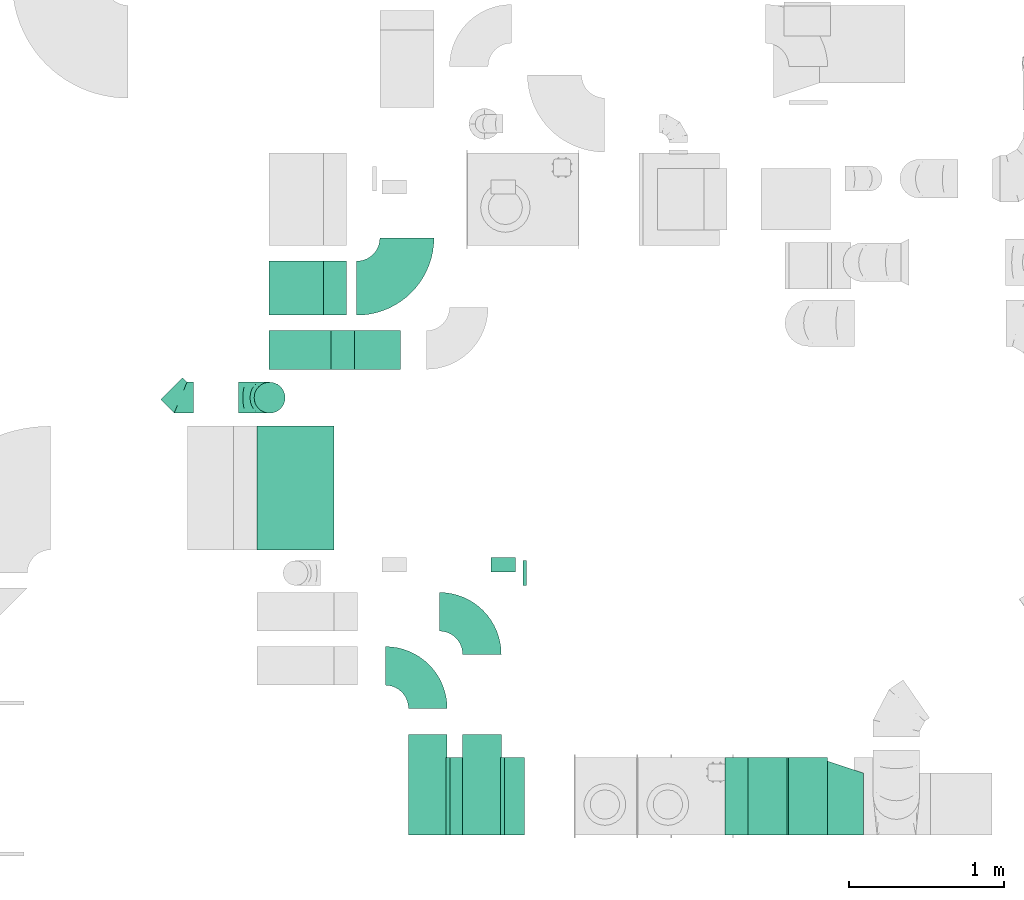
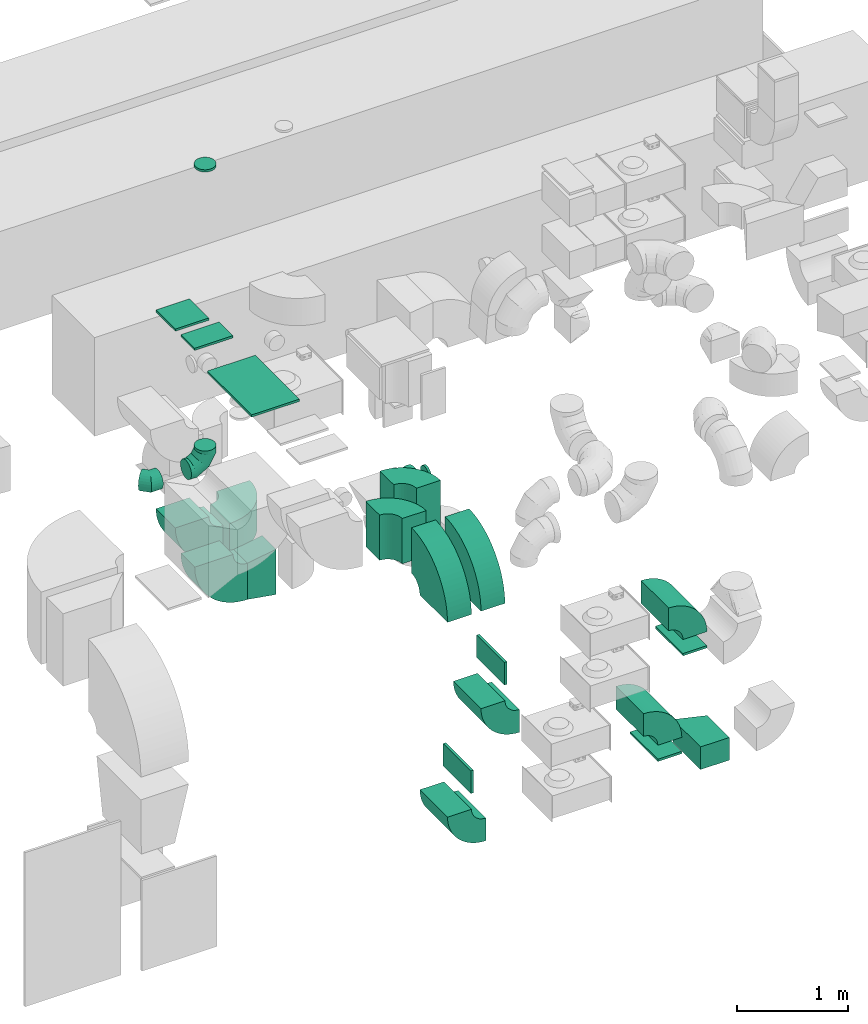
# One storey, part 8 of 59: 25 flow fittings.
"""IFC2X3 building model written with IfcOpenShell, lengths in millimetres."""

from ifc_helpers import new_model, entity, si_unit, converted_unit, derived_unit, direction, frame, frame_2d, origin, origin_2d_with_axis, place, context, subcontext, project, spatial, polyline, circle_curve, parameter, trimmed, segment, composite_curve, rectangle, circle, outline, extrude, faceted_brep, source, transform, mapped, material, type_object, type_shapes, element, save


model = new_model("IFC2X3")

# Units and contexts
model_context = context("Model", 3, precision=0.01, world=origin(), true_north=direction((6.12303176911189e-17, 1.0)))
body_context = subcontext(model_context, "Body", "Model", "MODEL_VIEW")
ifc_project = project(units=[si_unit("LENGTHUNIT", "METRE", prefix="MILLI"), si_unit("AREAUNIT", "SQUARE_METRE"), si_unit("VOLUMEUNIT", "CUBIC_METRE"), converted_unit("PLANEANGLEUNIT", "DEGREE", entity("IfcRatioMeasure", 0.0174532925199433), si_unit("PLANEANGLEUNIT", "RADIAN"), dimensions=[0, 0, 0, 0, 0, 0, 0]), si_unit("MASSUNIT", "GRAM", prefix="KILO"), derived_unit("MASSDENSITYUNIT", [(si_unit("MASSUNIT", "GRAM", prefix="KILO"), 1), (si_unit("LENGTHUNIT", "METRE"), -3)]), derived_unit("MOMENTOFINERTIAUNIT", [(si_unit("LENGTHUNIT", "METRE"), 4)]), si_unit("TIMEUNIT", "SECOND"), si_unit("FREQUENCYUNIT", "HERTZ"), si_unit("THERMODYNAMICTEMPERATUREUNIT", "DEGREE_CELSIUS"), derived_unit("THERMALTRANSMITTANCEUNIT", [(si_unit("MASSUNIT", "GRAM", prefix="KILO"), 1), (si_unit("THERMODYNAMICTEMPERATUREUNIT", "KELVIN"), -1), (si_unit("TIMEUNIT", "SECOND"), -3)]), derived_unit("VOLUMETRICFLOWRATEUNIT", [(si_unit("LENGTHUNIT", "METRE"), 3), (si_unit("TIMEUNIT", "SECOND"), -1)]), derived_unit("MASSFLOWRATEUNIT", [(si_unit("MASSUNIT", "GRAM", prefix="KILO"), 1), (si_unit("TIMEUNIT", "SECOND"), -1)]), derived_unit("ROTATIONALFREQUENCYUNIT", [(si_unit("TIMEUNIT", "SECOND"), -1)]), si_unit("ELECTRICCURRENTUNIT", "AMPERE"), si_unit("ELECTRICVOLTAGEUNIT", "VOLT"), si_unit("POWERUNIT", "WATT"), si_unit("FORCEUNIT", "NEWTON", prefix="KILO"), si_unit("ILLUMINANCEUNIT", "LUX"), si_unit("LUMINOUSFLUXUNIT", "LUMEN"), si_unit("LUMINOUSINTENSITYUNIT", "CANDELA"), derived_unit("USERDEFINED", [(si_unit("MASSUNIT", "GRAM", prefix="KILO"), -1), (si_unit("LENGTHUNIT", "METRE"), -2), (si_unit("TIMEUNIT", "SECOND"), 3), (si_unit("LUMINOUSFLUXUNIT", "LUMEN"), 1)]), derived_unit("LINEARVELOCITYUNIT", [(si_unit("LENGTHUNIT", "METRE"), 1), (si_unit("TIMEUNIT", "SECOND"), -1)]), si_unit("PRESSUREUNIT", "PASCAL"), derived_unit("USERDEFINED", [(si_unit("LENGTHUNIT", "METRE"), -2), (si_unit("MASSUNIT", "GRAM", prefix="KILO"), 1), (si_unit("TIMEUNIT", "SECOND"), -2)]), derived_unit("LINEARFORCEUNIT", [(si_unit("MASSUNIT", "GRAM", prefix="KILO"), 1), (si_unit("LENGTHUNIT", "METRE"), 1), (si_unit("TIMEUNIT", "SECOND"), -2), (si_unit("LENGTHUNIT", "METRE"), -1)]), derived_unit("PLANARFORCEUNIT", [(si_unit("MASSUNIT", "GRAM", prefix="KILO"), 1), (si_unit("LENGTHUNIT", "METRE"), 1), (si_unit("TIMEUNIT", "SECOND"), -2), (si_unit("LENGTHUNIT", "METRE"), -2)])], contexts=[model_context])

# Site, building, storey
site_placement = place(None, origin())
site = spatial("IfcSite", under=ifc_project, at=site_placement, CompositionType="ELEMENT")
building_placement = place(site_placement, origin())
building = spatial("IfcBuilding", under=site, at=building_placement, CompositionType="ELEMENT")
storey_placement = place(building_placement, frame((0.0, 0.0, 28200.0)))
storey = spatial("IfcBuildingStorey", under=building, at=storey_placement, CompositionType="ELEMENT", Elevation=28200.0)

# Flow fittings
ifc_material = material()
duct_fitting_type_1 = type_object("IfcDuctFittingType", PredefinedType="NOTDEFINED", material=ifc_material)
shared_shape_1 = source(origin(), body_context, "Body", "SweptSolid", [
    extrude(circle(Radius=79.9999999999994, at=origin_2d_with_axis()), frame((0.0, 0.0, 0.0), z_axis=(1.0, 0.0, 0.0), x_axis=(0.0, 1.0, 0.0)), (0.0, 0.0, 1.0), 25.0000000000018),
])
type_shapes(duct_fitting_type_1, [shared_shape_1])
flow_fitting_1_placement = place(storey_placement, frame((29294.64, 9627.84, 3205.01)))
element("IfcFlowFitting", 1, at=flow_fitting_1_placement, inside=storey, type_object=duct_fitting_type_1, material=ifc_material, context=body_context, shape_type="MappedRepresentation", body=[
    mapped(shared_shape_1, transform((0.0, 0.0, 0.0), scale=1.0)),
])
duct_fitting_type_2 = type_object("IfcDuctFittingType", PredefinedType="NOTDEFINED", material=ifc_material)
shared_shape_2 = source(origin(), body_context, "Body", "SweptSolid", [
    extrude(circle(Radius=99.9999999999994, at=origin_2d_with_axis()), frame((0.0, 0.0, 0.0), z_axis=(1.0, 0.0, 0.0), x_axis=(0.0, 1.0, 0.0)), (0.0, 0.0, 1.0), 25.0000000000018),
])
type_shapes(duct_fitting_type_2, [shared_shape_2])
flow_fitting_2_placement = place(storey_placement, frame((27656.97, 10761.91, 6490.0), z_axis=(-1.0, 0.0, 0.0), x_axis=(0.0, 0.0, 1.0)))
element("IfcFlowFitting", 2, at=flow_fitting_2_placement, inside=storey, type_object=duct_fitting_type_2, material=ifc_material, context=body_context, shape_type="MappedRepresentation", body=[
    mapped(shared_shape_2, transform((0.0, 0.0, 0.0), scale=1.0)),
])
duct_fitting_type_3 = type_object("IfcDuctFittingType", PredefinedType="NOTDEFINED", material=ifc_material)
shared_shape_3 = source(origin(), body_context, "Body", "SweptSolid", [
    extrude(outline(polyline([(-189.06, -221.94), (115.08, -221.94), (180.84, 172.62), (-106.86, 271.26), (-189.06, -221.94)])), frame((150.0, -125.0, 0.0), z_axis=(0.0, 1.0, 0.0), x_axis=(0.986393923832128, 0.0, -0.16439898730545)), (0.0, 0.0, 1.0), 250.0),
])
type_shapes(duct_fitting_type_3, [shared_shape_3])
flow_fitting_3_placement = place(storey_placement, frame((28504.24, 11070.06, 1600.0), z_axis=(0.0, 0.0, 1.0), x_axis=(-1.0, 0.0, 0.0)))
element("IfcFlowFitting", 3, at=flow_fitting_3_placement, inside=storey, type_object=duct_fitting_type_3, material=ifc_material, context=body_context, shape_type="MappedRepresentation", body=[
    mapped(shared_shape_3, transform((0.0, 0.0, 0.0), scale=1.0)),
])
duct_fitting_type_4 = type_object("IfcDuctFittingType", PredefinedType="NOTDEFINED", material=ifc_material)
shared_shape_4 = source(origin(), body_context, "Body", "SweptSolid", [
    extrude(rectangle(XDim=26.0960000000177, YDim=250.0, at=origin_2d_with_axis()), frame((6.95, 0.0, -250.0)), (0.0, 0.0, 1.0), 500.0),
])
type_shapes(duct_fitting_type_4, [shared_shape_4])
for number, where, z_axis, x_axis in (
    (4, (29155.0, 8184.5, 2075.0), (0.0, -1.0, 0.0), (1.0, 0.0, 0.0)),
    (5, (28805.03, 8184.5, 1000.0), (0.0, -1.0, 0.0), (1.0, 0.0, 0.0)),
):
    element("IfcFlowFitting", number, at=place(storey_placement, frame(where, z_axis=z_axis, x_axis=x_axis)), inside=storey, type_object=duct_fitting_type_4, material=ifc_material, context=body_context, shape_type="MappedRepresentation", body=[
        mapped(shared_shape_4, transform((0.0, 0.0, 0.0), scale=1.0)),
    ])
duct_fitting_type_5 = type_object("IfcDuctFittingType", PredefinedType="NOTDEFINED", material=ifc_material)
shared_shape_5 = source(origin(), body_context, "Body", "SweptSolid", [
    extrude(rectangle(XDim=500.0, YDim=26.0960000001386, at=origin_2d_with_axis()), frame((6.95, 0.0, -125.0), z_axis=(0.0, 0.0, 1.0), x_axis=(0.0, -1.0, 0.0)), (0.0, 0.0, 1.0), 250.0),
])
type_shapes(duct_fitting_type_5, [shared_shape_5])
for number, where, z_axis, x_axis in (
    (6, (31138.92, 8184.5, 1625.0), (-1.0, 0.0, 0.0), (0.0, 0.0, 1.0)),
    (7, (30876.33, 8184.5, 550.0), (-1.0, 0.0, 0.0), (0.0, 0.0, 1.0)),
):
    element("IfcFlowFitting", number, at=place(storey_placement, frame(where, z_axis=z_axis, x_axis=x_axis)), inside=storey, type_object=duct_fitting_type_5, material=ifc_material, context=body_context, shape_type="MappedRepresentation", body=[
        mapped(shared_shape_5, transform((0.0, 0.0, 0.0), scale=1.0)),
    ])
duct_fitting_type_6 = type_object("IfcDuctFittingType", PredefinedType="NOTDEFINED", material=ifc_material)
shared_shape_6 = source(origin(), body_context, "Body", "SweptSolid", [
    extrude(outline(polyline([(-86.97, -213.46), (229.26, -213.46), (71.16, 260.89), (-213.45, 166.02), (-86.97, -213.46)])), frame((150.0, -25.0, -125.0), z_axis=(0.0, 0.0, 1.0), x_axis=(0.948691527518346, -0.316203076542446, 0.0)), (0.0, 0.0, 1.0), 250.0),
])
type_shapes(duct_fitting_type_6, [shared_shape_6])
flow_fitting_4_placement = place(storey_placement, frame((31497.03, 8134.51, 425.0), z_axis=(0.0, 0.0, 1.0), x_axis=(-1.0, 0.0, 0.0)))
element("IfcFlowFitting", 8, at=flow_fitting_4_placement, inside=storey, type_object=duct_fitting_type_6, material=ifc_material, context=body_context, shape_type="MappedRepresentation", body=[
    mapped(shared_shape_6, transform((0.0, 0.0, 0.0), scale=1.0)),
])
duct_fitting_type_7 = type_object("IfcDuctFittingType", PredefinedType="NOTDEFINED", material=ifc_material)
shared_shape_7 = source(origin(), body_context, "Body", "SweptSolid", [
    extrude(rectangle(XDim=24.9999999999999, YDim=250.0, at=origin_2d_with_axis()), frame((12.5, 0.0, -200.0)), (0.0, 0.0, 1.0), 400.0),
])
type_shapes(duct_fitting_type_7, [shared_shape_7])
flow_fitting_5_placement = place(storey_placement, frame((27854.24, 11070.06, 4340.0), z_axis=(1.0, 0.0, 0.0), x_axis=(0.0, 0.0, 1.0)))
element("IfcFlowFitting", 9, at=flow_fitting_5_placement, inside=storey, type_object=duct_fitting_type_7, material=ifc_material, context=body_context, shape_type="MappedRepresentation", body=[
    mapped(shared_shape_7, transform((0.0, 0.0, 0.0), scale=1.0)),
])
duct_fitting_type_8 = type_object("IfcDuctFittingType", PredefinedType="NOTDEFINED", material=ifc_material)
shared_shape_8 = source(origin(), body_context, "Body", "SweptSolid", [
    extrude(rectangle(XDim=24.9999999999999, YDim=350.0, at=origin_2d_with_axis()), frame((12.5, 0.0, -175.0)), (0.0, 0.0, 1.0), 350.0),
])
type_shapes(duct_fitting_type_8, [shared_shape_8])
flow_fitting_6_placement = place(storey_placement, frame((27829.24, 11470.06, 4340.0), z_axis=(1.0, 0.0, 0.0), x_axis=(0.0, 0.0, 1.0)))
element("IfcFlowFitting", 10, at=flow_fitting_6_placement, inside=storey, type_object=duct_fitting_type_8, material=ifc_material, context=body_context, shape_type="MappedRepresentation", body=[
    mapped(shared_shape_8, transform((0.0, 0.0, 0.0), scale=1.0)),
])
duct_fitting_type_9 = type_object("IfcDuctFittingType", PredefinedType="NOTDEFINED", material=ifc_material)
shared_shape_9 = source(origin(), body_context, "Body", "SweptSolid", [
    extrude(rectangle(XDim=24.9999999999999, YDim=800.0, at=origin_2d_with_axis()), frame((12.5, 0.0, -250.0)), (0.0, 0.0, 1.0), 500.0),
])
type_shapes(duct_fitting_type_9, [shared_shape_9])
flow_fitting_7_placement = place(storey_placement, frame((27824.64, 10177.84, 4340.0), z_axis=(1.0, 0.0, 0.0), x_axis=(0.0, 0.0, 1.0)))
element("IfcFlowFitting", 11, at=flow_fitting_7_placement, inside=storey, type_object=duct_fitting_type_9, material=ifc_material, context=body_context, shape_type="MappedRepresentation", body=[
    mapped(shared_shape_9, transform((0.0, 0.0, 0.0), scale=1.0)),
])
duct_fitting_type_10 = type_object("IfcDuctFittingType", PredefinedType="NOTDEFINED", material=ifc_material)
shared_shape_10 = source(origin(), body_context, "Body", "Brep", [
    faceted_brep([(-200.0, 0.0, -100.0), (-200.0, -25.88, -96.59), (-200.0, -50.0, -86.6), (-200.0, -70.71, -70.71), (-200.0, -86.6, -50.0), (-200.0, -96.59, -25.88), (-200.0, -100.0, 0.0), (-200.0, -96.59, 25.88), (-200.0, -86.6, 50.0), (-200.0, -70.71, 70.71), (-200.0, -50.0, 86.6), (-200.0, -25.88, 96.59), (-200.0, 0.0, 100.0), (-200.0, 25.88, 96.59), (-200.0, 50.0, 86.6), (-200.0, 70.71, 70.71), (-200.0, 86.6, 50.0), (-200.0, 96.59, 25.88), (-200.0, 100.0, 0.0), (-200.0, 96.59, -25.88), (-200.0, 86.6, -50.0), (-200.0, 70.71, -70.71), (-200.0, 50.0, -86.6), (-200.0, 25.88, -96.59), (-153.35, 25.88, 96.59), (-159.81, 50.0, 86.6), (-146.41, 0.0, 100.0), (-165.36, 70.71, 70.71), (-172.29, 96.59, 25.88), (-173.21, 100.0, 0.0), (-169.62, 86.6, 50.0), (-169.62, 86.6, -50.0), (-165.36, 70.71, -70.71), (-172.29, 96.59, -25.88), (-153.35, 25.88, -96.59), (-146.41, 0.0, -100.0), (-159.81, 50.0, -86.6), (-139.48, -25.88, -96.59), (-133.01, -50.0, -86.6), (-127.46, -70.71, -70.71), (-123.21, -86.6, -50.0), (-120.53, -96.59, -25.88), (-119.62, -100.0, 0.0), (-120.53, -96.59, 25.88), (-123.21, -86.6, 50.0), (-127.46, -70.71, 70.71), (-133.01, -50.0, 86.6), (-139.48, -25.88, 96.59), (-72.54, 72.54, 96.59), (-90.19, 90.19, 86.6), (-53.59, 53.59, 100.0), (-105.35, 105.35, 70.71), (-116.99, 116.99, 50.0), (-124.3, 124.3, 25.88), (-126.79, 126.79, 0.0), (-124.3, 124.3, -25.88), (-116.99, 116.99, -50.0), (-105.35, 105.35, -70.71), (-72.54, 72.54, -96.59), (-53.59, 53.59, -100.0), (-90.19, 90.19, -86.6), (-34.64, 34.64, -96.59), (-16.99, 16.99, -86.6), (-1.83, 1.83, -70.71), (9.81, -9.81, -50.0), (17.12, -17.12, -25.88), (19.62, -19.62, 0.0), (17.12, -17.12, 25.88), (9.81, -9.81, 50.0), (-1.83, 1.83, 70.71), (-16.99, 16.99, 86.6), (-34.64, 34.64, 96.59), (-25.88, 153.35, 96.59), (-50.0, 159.81, 86.6), (0.0, 146.41, 100.0), (-70.71, 165.36, 70.71), (-86.6, 169.62, 50.0), (-96.59, 172.29, 25.88), (-100.0, 173.21, 0.0), (-96.59, 172.29, -25.88), (-86.6, 169.62, -50.0), (-70.71, 165.36, -70.71), (-25.88, 153.35, -96.59), (0.0, 146.41, -100.0), (-50.0, 159.81, -86.6), (25.88, 139.48, -96.59), (50.0, 133.01, -86.6), (70.71, 127.46, -70.71), (86.6, 123.21, -50.0), (96.59, 120.53, -25.88), (100.0, 119.62, 0.0), (96.59, 120.53, 25.88), (86.6, 123.21, 50.0), (70.71, 127.46, 70.71), (50.0, 133.01, 86.6), (25.88, 139.48, 96.59), (-25.88, 200.0, -96.59), (-50.0, 200.0, -86.6), (-70.71, 200.0, -70.71), (-86.6, 200.0, -50.0), (-96.59, 200.0, -25.88), (-100.0, 200.0, 0.0), (-96.59, 200.0, 25.88), (-86.6, 200.0, 50.0), (-70.71, 200.0, 70.71), (-50.0, 200.0, 86.6), (-25.88, 200.0, 96.59), (0.0, 200.0, 100.0), (25.88, 200.0, 96.59), (50.0, 200.0, 86.6), (70.71, 200.0, 70.71), (86.6, 200.0, 50.0), (96.59, 200.0, 25.88), (100.0, 200.0, 0.0), (96.59, 200.0, -25.88), (86.6, 200.0, -50.0), (70.71, 200.0, -70.71), (50.0, 200.0, -86.6), (25.88, 200.0, -96.59), (0.0, 200.0, -100.0)], [[[0, 1, 2, 3, 4, 5, 6, 7, 8, 9, 10, 11, 12, 13, 14, 15, 16, 17, 18, 19, 20, 21, 22, 23]], [[24, 25, 14, 13]], [[26, 24, 13, 12]], [[14, 25, 27, 15]], [[28, 29, 18, 17]], [[30, 28, 17, 16]], [[15, 27, 30, 16]], [[20, 31, 32, 21]], [[33, 31, 20, 19]], [[18, 29, 33, 19]], [[34, 35, 0, 23]], [[36, 34, 23, 22]], [[32, 36, 22, 21]], [[1, 0, 35, 37]], [[2, 1, 37, 38]], [[38, 39, 3, 2]], [[5, 4, 40, 41]], [[6, 5, 41, 42]], [[39, 40, 4, 3]], [[6, 42, 43, 7]], [[7, 43, 44, 8]], [[8, 44, 45, 9]], [[9, 45, 46, 10]], [[10, 46, 47, 11]], [[26, 12, 11, 47]], [[48, 49, 25, 24]], [[50, 48, 24, 26]], [[27, 25, 49, 51]], [[52, 53, 28, 30]], [[51, 52, 30, 27]], [[29, 28, 53, 54]], [[55, 56, 31, 33]], [[54, 55, 33, 29]], [[32, 31, 56, 57]], [[58, 59, 35, 34]], [[60, 58, 34, 36]], [[57, 60, 36, 32]], [[37, 35, 59, 61]], [[38, 37, 61, 62]], [[39, 38, 62, 63]], [[41, 40, 64, 65]], [[42, 41, 65, 66]], [[63, 64, 40, 39]], [[43, 42, 66, 67]], [[44, 43, 67, 68]], [[68, 69, 45, 44]], [[46, 45, 69, 70]], [[47, 46, 70, 71]], [[26, 47, 71, 50]], [[72, 73, 49, 48]], [[74, 72, 48, 50]], [[51, 49, 73, 75]], [[76, 77, 53, 52]], [[75, 76, 52, 51]], [[54, 53, 77, 78]], [[79, 80, 56, 55]], [[78, 79, 55, 54]], [[57, 56, 80, 81]], [[82, 83, 59, 58]], [[84, 82, 58, 60]], [[81, 84, 60, 57]], [[61, 59, 83, 85]], [[62, 61, 85, 86]], [[63, 62, 86, 87]], [[65, 64, 88, 89]], [[66, 65, 89, 90]], [[87, 88, 64, 63]], [[67, 66, 90, 91]], [[68, 67, 91, 92]], [[92, 93, 69, 68]], [[70, 69, 93, 94]], [[71, 70, 94, 95]], [[50, 71, 95, 74]], [[96, 97, 98, 99, 100, 101, 102, 103, 104, 105, 106, 107, 108, 109, 110, 111, 112, 113, 114, 115, 116, 117, 118, 119]], [[72, 74, 107, 106]], [[73, 72, 106, 105]], [[75, 73, 105, 104]], [[102, 101, 78, 77]], [[103, 102, 77, 76]], [[75, 104, 103, 76]], [[78, 101, 100, 79]], [[79, 100, 99, 80]], [[80, 99, 98, 81]], [[84, 97, 96, 82]], [[82, 96, 119, 83]], [[84, 81, 98, 97]], [[118, 117, 86, 85]], [[119, 118, 85, 83]], [[116, 87, 86, 117]], [[88, 115, 114, 89]], [[89, 114, 113, 90]], [[115, 88, 87, 116]], [[91, 90, 113, 112]], [[92, 91, 112, 111]], [[111, 110, 93, 92]], [[95, 94, 109, 108]], [[74, 95, 108, 107]], [[110, 109, 94, 93]]]),
])
type_shapes(duct_fitting_type_10, [shared_shape_10])
flow_fitting_8_placement = place(storey_placement, frame((27656.97, 10761.91, 3210.11), z_axis=(0.0, -1.0, 0.0), x_axis=(1.0, 0.0, 0.0)))
element("IfcFlowFitting", 12, at=flow_fitting_8_placement, inside=storey, type_object=duct_fitting_type_10, material=ifc_material, context=body_context, shape_type="MappedRepresentation", body=[
    mapped(shared_shape_10, transform((0.0, 0.0, 0.0), scale=1.0)),
])
duct_fitting_type_11 = type_object("IfcDuctFittingType", PredefinedType="NOTDEFINED", material=ifc_material)
shared_shape_11 = source(origin(), body_context, "Body", "Brep", [
    faceted_brep([(-82.84, 0.0, -100.0), (-82.84, -25.88, -96.59), (-82.84, -50.0, -86.6), (-82.84, -70.71, -70.71), (-82.84, -86.6, -50.0), (-82.84, -96.59, -25.88), (-82.84, -100.0, 0.0), (-82.84, -96.59, 25.88), (-82.84, -86.6, 50.0), (-82.84, -70.71, 70.71), (-82.84, -50.0, 86.6), (-82.84, -25.88, 96.59), (-82.84, 0.0, 100.0), (-82.84, 25.88, 96.59), (-82.84, 50.0, 86.6), (-82.84, 70.71, 70.71), (-82.84, 86.6, 50.0), (-82.84, 96.59, 25.88), (-82.84, 100.0, 0.0), (-82.84, 96.59, -25.88), (-82.84, 86.6, -50.0), (-82.84, 70.71, -70.71), (-82.84, 50.0, -86.6), (-82.84, 25.88, -96.59), (-10.72, 25.88, 96.59), (-20.71, 50.0, 86.6), (0.0, 0.0, 100.0), (-29.29, 70.71, 70.71), (-35.87, 86.6, 50.0), (-40.01, 96.59, 25.88), (-41.42, 100.0, 0.0), (-40.01, 96.59, -25.88), (-35.87, 86.6, -50.0), (-29.29, 70.71, -70.71), (-10.72, 25.88, -96.59), (0.0, 0.0, -100.0), (-20.71, 50.0, -86.6), (10.72, -25.88, -96.59), (20.71, -50.0, -86.6), (29.29, -70.71, -70.71), (35.87, -86.6, -50.0), (40.01, -96.59, -25.88), (41.42, -100.0, 0.0), (40.01, -96.59, 25.88), (35.87, -86.6, 50.0), (29.29, -70.71, 70.71), (20.71, -50.0, 86.6), (10.72, -25.88, 96.59), (58.58, 58.58, 100.0), (40.28, 76.88, 96.59), (23.22, 93.93, 86.6), (8.58, 108.58, 70.71), (-2.66, 119.82, 50.0), (-9.72, 126.88, 25.88), (-12.13, 129.29, 0.0), (-9.72, 126.88, -25.88), (-2.66, 119.82, -50.0), (8.58, 108.58, -70.71), (23.22, 93.93, -86.6), (40.28, 76.88, -96.59), (58.58, 58.58, -100.0), (76.88, 40.28, -96.59), (93.93, 23.22, -86.6), (108.58, 8.58, -70.71), (119.82, -2.66, -50.0), (126.88, -9.72, -25.88), (129.29, -12.13, 0.0), (126.88, -9.72, 25.88), (119.82, -2.66, 50.0), (108.58, 8.58, 70.71), (93.93, 23.22, 86.6), (76.88, 40.28, 96.59)], [[[0, 1, 2, 3, 4, 5, 6, 7, 8, 9, 10, 11, 12, 13, 14, 15, 16, 17, 18, 19, 20, 21, 22, 23]], [[24, 25, 14, 13]], [[26, 24, 13, 12]], [[14, 25, 27, 15]], [[28, 29, 17, 16]], [[28, 16, 15, 27]], [[30, 18, 17, 29]], [[31, 32, 20, 19]], [[30, 31, 19, 18]], [[32, 33, 21, 20]], [[34, 35, 0, 23]], [[36, 34, 23, 22]], [[33, 36, 22, 21]], [[1, 0, 35, 37]], [[2, 1, 37, 38]], [[38, 39, 3, 2]], [[5, 4, 40, 41]], [[6, 5, 41, 42]], [[39, 40, 4, 3]], [[6, 42, 43, 7]], [[7, 43, 44, 8]], [[8, 44, 45, 9]], [[9, 45, 46, 10]], [[10, 46, 47, 11]], [[26, 12, 11, 47]], [[24, 26, 48, 49]], [[25, 24, 49, 50]], [[27, 25, 50, 51]], [[29, 28, 52, 53]], [[30, 29, 53, 54]], [[51, 52, 28, 27]], [[30, 54, 55, 31]], [[31, 55, 56, 32]], [[57, 33, 32, 56]], [[36, 58, 59, 34]], [[34, 59, 60, 35]], [[58, 36, 33, 57]], [[35, 60, 61, 37]], [[37, 61, 62, 38]], [[63, 39, 38, 62]], [[40, 64, 65, 41]], [[41, 65, 66, 42]], [[64, 40, 39, 63]], [[43, 42, 66, 67]], [[44, 43, 67, 68]], [[68, 69, 45, 44]], [[47, 46, 70, 71]], [[26, 47, 71, 48]], [[69, 70, 46, 45]], [[59, 58, 57, 56, 55, 54, 53, 52, 51, 50, 49, 48, 71, 70, 69, 68, 67, 66, 65, 64, 63, 62, 61, 60]]]),
])
type_shapes(duct_fitting_type_11, [shared_shape_11])
flow_fitting_9_placement = place(storey_placement, frame((27080.99, 10761.91, 3210.11), z_axis=(0.0, 0.0, 1.0), x_axis=(0.70710678118647, -0.707106781186626, 0.0)))
element("IfcFlowFitting", 13, at=flow_fitting_9_placement, inside=storey, type_object=duct_fitting_type_11, material=ifc_material, context=body_context, shape_type="MappedRepresentation", body=[
    mapped(shared_shape_11, transform((0.0, 0.0, 0.0), scale=1.0)),
])
duct_fitting_type_12 = type_object("IfcDuctFittingType", PredefinedType="NOTDEFINED", material=ifc_material)
shared_shape_12 = source(origin(), body_context, "Body", "Brep", [
    faceted_brep([(20.0, 20.71, -77.27), (20.0, 40.0, -69.28), (20.0, 56.57, -56.57), (20.0, 69.28, -40.0), (20.0, 77.27, -20.71), (20.0, 80.0, 0.0), (20.0, 77.27, 20.71), (20.0, 69.28, 40.0), (20.0, 56.57, 56.57), (20.0, 40.0, 69.28), (20.0, 20.71, 77.27), (20.0, 0.0, 80.0), (20.0, -20.71, 77.27), (20.0, -40.0, 69.28), (20.0, -56.57, 56.57), (20.0, -69.28, 40.0), (20.0, -77.27, 20.71), (20.0, -80.0, 0.0), (20.0, -77.27, -20.71), (20.0, -69.28, -40.0), (20.0, -56.57, -56.57), (20.0, -40.0, -69.28), (20.0, -20.71, -77.27), (20.0, 0.0, -80.0), (0.0, 0.0, 80.0), (0.0, 20.71, 77.27), (-73.9, 20.71, 77.27), (-73.9, 0.0, 80.0), (0.0, 40.0, 69.28), (-73.9, 40.0, 69.28), (0.0, 56.57, 56.57), (-73.9, 56.57, 56.57), (0.0, 69.28, 40.0), (0.0, 77.27, 20.71), (-73.9, 77.27, 20.71), (-73.9, 69.28, 40.0), (0.0, 80.0, 0.0), (-73.9, 80.0, 0.0), (0.0, 77.27, -20.71), (-73.9, 77.27, -20.71), (0.0, 69.28, -40.0), (-73.9, 69.28, -40.0), (0.0, 56.57, -56.57), (-73.9, 56.57, -56.57), (0.0, 40.0, -69.28), (0.0, 20.71, -77.27), (-73.9, 20.71, -77.27), (-73.9, 40.0, -69.28), (0.0, 0.0, -80.0), (-73.9, 0.0, -80.0), (0.0, -20.71, -77.27), (-73.9, -20.71, -77.27), (0.0, -40.0, -69.28), (-73.9, -40.0, -69.28), (0.0, -56.57, -56.57), (-73.9, -56.57, -56.57), (0.0, -69.28, -40.0), (0.0, -77.27, -20.71), (-73.9, -77.27, -20.71), (-73.9, -69.28, -40.0), (0.0, -80.0, 0.0), (-73.9, -80.0, 0.0), (0.0, -77.27, 20.71), (-73.9, -77.27, 20.71), (0.0, -69.28, 40.0), (-73.9, -69.28, 40.0), (0.0, -56.57, 56.57), (-73.9, -56.57, 56.57), (0.0, -40.0, 69.28), (0.0, -20.71, 77.27), (-73.9, -20.71, 77.27), (-73.9, -40.0, 69.28)], [[[0, 1, 2, 3, 4, 5, 6, 7, 8, 9, 10, 11, 12, 13, 14, 15, 16, 17, 18, 19, 20, 21, 22, 23]], [[24, 11, 10, 25, 26, 27]], [[25, 10, 9, 28, 29, 26]], [[28, 9, 8, 30, 31, 29]], [[32, 7, 6, 33, 34, 35]], [[33, 6, 5, 36, 37, 34]], [[30, 8, 7, 32, 35, 31]], [[36, 5, 4, 38, 39, 37]], [[38, 4, 3, 40, 41, 39]], [[40, 3, 2, 42, 43, 41]], [[44, 1, 0, 45, 46, 47]], [[45, 0, 23, 48, 49, 46]], [[42, 2, 1, 44, 47, 43]], [[48, 23, 22, 50, 51, 49]], [[50, 22, 21, 52, 53, 51]], [[52, 21, 20, 54, 55, 53]], [[56, 19, 18, 57, 58, 59]], [[57, 18, 17, 60, 61, 58]], [[54, 20, 19, 56, 59, 55]], [[60, 17, 16, 62, 63, 61]], [[62, 16, 15, 64, 65, 63]], [[64, 15, 14, 66, 67, 65]], [[68, 13, 12, 69, 70, 71]], [[69, 12, 11, 24, 27, 70]], [[66, 14, 13, 68, 71, 67]], [[49, 51, 53, 55, 59, 58, 61, 63, 65, 67, 71, 70, 27, 26, 29, 31, 35, 34, 37, 39, 41, 43, 47, 46]]]),
])
type_shapes(duct_fitting_type_12, [shared_shape_12])
flow_fitting_10_placement = place(storey_placement, frame((29167.12, 9707.84, 3205.01), z_axis=(0.0, 0.0, -1.0), x_axis=(0.0, 1.0, 0.0)))
element("IfcFlowFitting", 14, at=flow_fitting_10_placement, inside=storey, type_object=duct_fitting_type_12, material=ifc_material, context=body_context, shape_type="MappedRepresentation", body=[
    mapped(shared_shape_12, transform((0.0, 0.0, 0.0), scale=1.0)),
])
duct_fitting_type_13 = type_object("IfcDuctFittingType", PredefinedType="NOTDEFINED", material=ifc_material)
shared_shape_13 = source(origin(), body_context, "Body", "SweptSolid", [
    extrude(outline(composite_curve([segment(polyline([(-450.0, -200.0), (50.0, -200.0)]), True, "CONTINUOUS"), segment(trimmed(circle_curve(frame_2d((200.0, -200.0), x_axis=(0.0, 1.0)), 150.0), [parameter(0.0)], [parameter(90.0000000000001)], True, "PARAMETER"), False, "CONTINUOUS"), segment(polyline([(200.0, -50.0), (200.0, 450.0)]), True, "CONTINUOUS"), segment(trimmed(circle_curve(frame_2d((200.0, -200.0), x_axis=(0.0, 1.0)), 650.0), [parameter(0.0)], [parameter(90.0000000000001)], True, "PARAMETER"), True, "CONTINUOUS")], self_intersect=False)), frame((-200.0, 200.0, -125.0), z_axis=(0.0, 0.0, 1.0), x_axis=(-1.0, 0.0, 0.0)), (0.0, 0.0, 1.0), 250.0),
])
type_shapes(duct_fitting_type_13, [shared_shape_13])
for number, where, z_axis, x_axis in (
    (15, (29030.0, 8184.5, 3250.0), (1.0, 0.0, 0.0), (0.0, -1.0, 0.0)),
    (16, (28680.03, 8184.5, 3250.0), (1.0, 0.0, 0.0), (0.0, -1.0, 0.0)),
):
    element("IfcFlowFitting", number, at=place(storey_placement, frame(where, z_axis=z_axis, x_axis=x_axis)), inside=storey, type_object=duct_fitting_type_13, material=ifc_material, context=body_context, shape_type="MappedRepresentation", body=[
        mapped(shared_shape_13, transform((0.0, 0.0, 0.0), scale=1.0)),
    ])
duct_fitting_type_14 = type_object("IfcDuctFittingType", PredefinedType="NOTDEFINED", material=ifc_material)
shared_shape_14 = source(origin(), body_context, "Body", "SweptSolid", [
    extrude(outline(composite_curve([segment(polyline([(-262.5, -137.5), (-12.5, -137.5)]), True, "CONTINUOUS"), segment(trimmed(circle_curve(frame_2d((137.5, -137.5), x_axis=(0.0, 1.0)), 150.0), [parameter(0.0)], [parameter(90.0000000000001)], True, "PARAMETER"), False, "CONTINUOUS"), segment(polyline([(137.5, 12.5), (137.5, 262.5)]), True, "CONTINUOUS"), segment(trimmed(circle_curve(frame_2d((137.5, -137.5), x_axis=(0.0, 1.0)), 400.0), [parameter(0.0)], [parameter(90.0000000000001)], True, "PARAMETER"), True, "CONTINUOUS")], self_intersect=False)), frame((-137.5, 137.5, -250.0), z_axis=(0.0, 0.0, 1.0), x_axis=(-1.0, 0.0, 0.0)), (0.0, 0.0, 1.0), 500.0),
])
type_shapes(duct_fitting_type_14, [shared_shape_14])
for number, where, z_axis, x_axis in (
    (17, (29030.0, 9377.5, 3250.0), (0.0, 0.0, 1.0), (0.0, 1.0, 0.0)),
    (18, (29030.0, 8184.5, 1500.0), (0.0, -1.0, 0.0), (0.0, 0.0, -1.0)),
    (19, (31138.92, 8184.5, 2075.0), (0.0, 1.0, 0.0), (1.0, 0.0, 0.0)),
    (20, (28680.03, 9027.5, 3250.0), (0.0, 0.0, 1.0), (0.0, 1.0, 0.0)),
    (21, (28680.03, 8184.5, 425.0), (0.0, -1.0, 0.0), (0.0, 0.0, -1.0)),
    (22, (30876.33, 8184.5, 1000.0), (0.0, -1.0, 0.0), (0.0, 0.0, 1.0)),
):
    element("IfcFlowFitting", number, at=place(storey_placement, frame(where, z_axis=z_axis, x_axis=x_axis)), inside=storey, type_object=duct_fitting_type_14, material=ifc_material, context=body_context, shape_type="MappedRepresentation", body=[
        mapped(shared_shape_14, transform((0.0, 0.0, 0.0), scale=1.0)),
    ])
duct_fitting_type_15 = type_object("IfcDuctFittingType", PredefinedType="NOTDEFINED", material=ifc_material)
shared_shape_15 = source(origin(), body_context, "Body", "SweptSolid", [
    extrude(outline(composite_curve([segment(polyline([(-375.0, -175.0), (25.0, -175.0)]), True, "CONTINUOUS"), segment(trimmed(circle_curve(frame_2d((175.0, -175.0), x_axis=(0.0, 1.0)), 150.0), [parameter(0.0)], [parameter(90.0000000000001)], True, "PARAMETER"), False, "CONTINUOUS"), segment(polyline([(175.0, -25.0), (175.0, 375.0)]), True, "CONTINUOUS"), segment(trimmed(circle_curve(frame_2d((175.0, -175.0), x_axis=(0.0, 1.0)), 550.0), [parameter(0.0)], [parameter(90.0)], True, "PARAMETER"), True, "CONTINUOUS")], self_intersect=False)), frame((-175.0, 175.0, -125.0), z_axis=(0.0, 0.0, 1.0), x_axis=(-1.0, 0.0, 0.0)), (0.0, 0.0, 1.0), 250.0),
])
type_shapes(duct_fitting_type_15, [shared_shape_15])
flow_fitting_11_placement = place(storey_placement, frame((27854.24, 11070.06, 1600.01), z_axis=(0.0, 1.0, 0.0), x_axis=(-1.0, 0.0, 0.0)))
element("IfcFlowFitting", 23, at=flow_fitting_11_placement, inside=storey, type_object=duct_fitting_type_15, material=ifc_material, context=body_context, shape_type="MappedRepresentation", body=[
    mapped(shared_shape_15, transform((0.0, 0.0, 0.0), scale=1.0)),
])
duct_fitting_type_16 = type_object("IfcDuctFittingType", PredefinedType="NOTDEFINED", material=ifc_material)
shared_shape_16 = source(origin(), body_context, "Body", "SweptSolid", [
    extrude(outline(composite_curve([segment(polyline([(-337.5, -162.5), (12.5, -162.5)]), True, "CONTINUOUS"), segment(trimmed(circle_curve(frame_2d((162.5, -162.5), x_axis=(0.0, 1.0)), 150.0), [parameter(0.0)], [parameter(90.0)], True, "PARAMETER"), False, "CONTINUOUS"), segment(polyline([(162.5, -12.5), (162.5, 337.5)]), True, "CONTINUOUS"), segment(trimmed(circle_curve(frame_2d((162.5, -162.5), x_axis=(0.0, 1.0)), 500.0), [parameter(0.0)], [parameter(90.0)], True, "PARAMETER"), True, "CONTINUOUS")], self_intersect=False)), frame((-162.5, 162.5, -175.0), z_axis=(0.0, 0.0, 1.0), x_axis=(-1.0, 0.0, 0.0)), (0.0, 0.0, 1.0), 350.0),
])
type_shapes(duct_fitting_type_16, [shared_shape_16])
flow_fitting_12_placement = place(storey_placement, frame((27829.24, 11470.06, 1845.0), z_axis=(0.0, -1.0, 0.0), x_axis=(0.0, 0.0, -1.0)))
element("IfcFlowFitting", 24, at=flow_fitting_12_placement, inside=storey, type_object=duct_fitting_type_16, material=ifc_material, context=body_context, shape_type="MappedRepresentation", body=[
    mapped(shared_shape_16, transform((0.0, 0.0, 0.0), scale=1.0)),
])
flow_fitting_13_placement = place(storey_placement, frame((28545.03, 11470.06, 1845.0)))
element("IfcFlowFitting", 25, at=flow_fitting_13_placement, inside=storey, type_object=duct_fitting_type_16, material=ifc_material, context=body_context, shape_type="MappedRepresentation", body=[
    mapped(shared_shape_16, transform((0.0, 0.0, 0.0), scale=1.0)),
])

save(model, "model.ifc")
